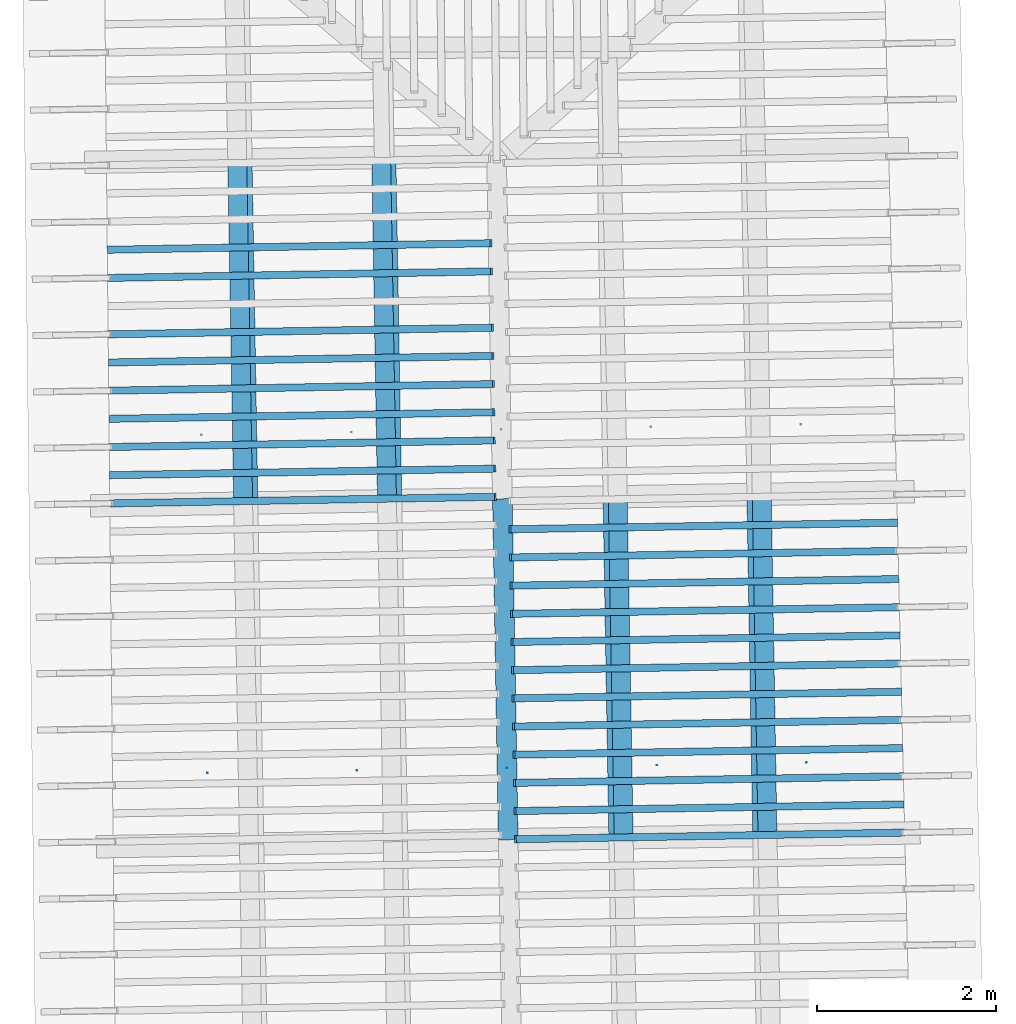
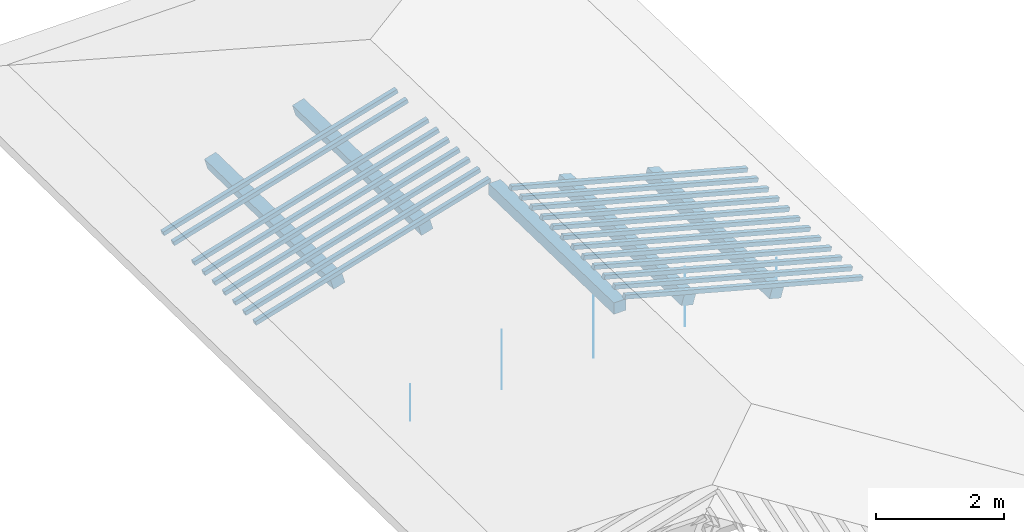
# One storey, part 5 of 19: 22 beams, 5 members, 2 elements without a shape of their own.
"""IFC4 building model written with IfcOpenShell, lengths in metres."""

from ifc_helpers import new_model, entity, si_unit, converted_unit, derived_unit, direction, frame, origin, place, context, subcontext, project, spatial, arc, indexed_curve, outline, extrude, source, transform, mapped, material, type_object, type_shapes, element, aggregate, save


model = new_model("IFC4")

# Units and contexts
model_context = context("Model", 3, precision=1e-05, world=origin(), true_north=direction((6.123233995736766e-17, 1.0)))
body_context = subcontext(model_context, "Body", "Model", "MODEL_VIEW")
ifc_project = project(units=[si_unit("LENGTHUNIT", "METRE"), si_unit("AREAUNIT", "SQUARE_METRE"), si_unit("VOLUMEUNIT", "CUBIC_METRE"), converted_unit("PLANEANGLEUNIT", "DEGREE", entity("IfcPlaneAngleMeasure", 0.017453292519943278), si_unit("PLANEANGLEUNIT", "RADIAN"), dimensions=[0, 0, 0, 0, 0, 0, 0]), derived_unit("THERMALTRANSMITTANCEUNIT", [(si_unit("MASSUNIT", "GRAM", prefix="KILO"), 1), (si_unit("THERMODYNAMICTEMPERATUREUNIT", "KELVIN"), -1), (si_unit("TIMEUNIT", "SECOND"), -3)])], contexts=[model_context])

# Site, building, storey
site_placement = place(None, origin())
site = spatial("IfcSite", under=ifc_project, at=site_placement, CompositionType="ELEMENT")
building_placement = place(site_placement, origin())
building = spatial("IfcBuilding", under=site, at=building_placement, CompositionType="ELEMENT")
storey_placement = place(building_placement, frame((0.0, 0.0, 3.28)))
storey = spatial("IfcBuildingStorey", under=building, at=storey_placement, Name="Livello Copertura", CompositionType="ELEMENT", Elevation=3.28)

# Members
ifc_material_1 = material(Name="Legno - Legno da costruzione", Category="Legno")
member_type_1 = type_object("IfcMemberType", Name="Legno:220x220", PredefinedType="PURLIN", material=ifc_material_1)
shared_shape_1 = source(origin(), body_context, "Body", "SweptSolid", [
    extrude(outline(indexed_curve([(-1.9059999897376847, -0.11000000000000167), (1.9059999897376847, -0.11000000000000167), (1.9059999897376847, 0.11000000000000167), (-1.9059999897376847, 0.11000000000000167), (-1.9059999897376847, -0.11000000000000167)], self_intersect=False)), frame((1.0262315541353928e-08, 0.0, -0.11000000000000543), z_axis=(0.0, 0.0, 1.0), x_axis=(-1.0, 0.0, 0.0)), (0.0, 0.0, 1.0), 0.21999999999999986),
])
type_shapes(member_type_1, [shared_shape_1])
member_placement = place(storey_placement, frame((-0.2062576255729681, 6.6317139072139595, 1.12884073837279), z_axis=(0.0, 0.0, 1.0), x_axis=(0.017084897015610563, -0.9998540424951864, 0.0)))
element("IfcMember", 1, at=member_placement, inside=storey, type_object=member_type_1, material=ifc_material_1, Name="Legno:220x220", ObjectType="Legno:220x220", PredefinedType="PURLIN", context=body_context, shape_type="MappedRepresentation", body=[
    mapped(shared_shape_1, transform((0.0, 0.0, 0.0), scale=1.0)),
])
member_type_2 = type_object("IfcMemberType", Name="Legno:220x220", PredefinedType="PURLIN", material=ifc_material_1)
shared_shape_2 = source(origin(), body_context, "Body", "SweptSolid", [
    extrude(outline(indexed_curve([(-1.905999989737685, -0.11000000000000167), (1.9059999897376847, -0.11000000000000167), (1.905999989737685, 0.11000000000000167), (-1.905999989737685, 0.11000000000000167), (-1.905999989737685, -0.11000000000000167)], self_intersect=False)), frame((1.0262315338316342e-08, 0.0, -0.11000000000000543), z_axis=(0.0, 0.0, 1.0), x_axis=(-1.0, 0.0, 0.0)), (0.0, 0.0, 1.0), 0.21999999999999986),
])
type_shapes(member_type_2, [shared_shape_2])
for number, where, z_axis, x_axis, name in (
    (2, (1.0540890021597151, 6.653124444591353, 0.8159721265451645), (0.2688805697492535, 0.004594467440668277, 0.9631625667976581), (0.01708489701561056, -0.9998540424951863, 0.0), "Legno:220x220"),
    (3, (2.6621509365891316, 6.680506746443959, 0.36692808026980417), (0.2688805697492535, 0.004594467440668277, 0.9631625667976581), (0.01708489701561056, -0.9998540424951863, 0.0), "Legno:220x220"),
):
    element("IfcMember", number, at=place(storey_placement, frame(where, z_axis=z_axis, x_axis=x_axis)), inside=storey, type_object=member_type_2, material=ifc_material_1, Name=name, ObjectType="Legno:220x220", PredefinedType="PURLIN", context=body_context, shape_type="MappedRepresentation", body=[
        mapped(shared_shape_2, transform((0.0, 0.0, 0.0), scale=1.0)),
    ])
member_type_3 = type_object("IfcMemberType", Name="Legno:220x220", PredefinedType="PURLIN", material=ifc_material_1)
shared_shape_3 = source(origin(), body_context, "Body", "SweptSolid", [
    extrude(outline(indexed_curve([(-1.9189999897376846, -0.11000000000000167), (1.9189999897376848, -0.11000000000000167), (1.9189999897376846, 0.11000000000000167), (-1.9189999897376846, 0.11000000000000167), (-1.9189999897376846, -0.11000000000000167)], self_intersect=False)), frame((1.0262315473674733e-08, 0.0, -0.11000000000000543), z_axis=(0.0, 0.0, 1.0), x_axis=(-1.0, 0.0, 0.0)), (0.0, 0.0, 1.0), 0.21999999999999986),
])
type_shapes(member_type_3, [shared_shape_3])
for number, where, z_axis, x_axis, name in (
    (4, (-1.5319733064987866, 10.434952193913192, 0.8160286470518429), (-0.2688805697492535, -0.0045944674406682715, 0.9631625667976581), (0.017084897015610542, -0.9998540424951863, 0.0), "Legno:220x220"),
    (5, (-3.1400352409282095, 10.40756989206059, 0.366984600776487), (-0.2688805697492535, -0.0045944674406682715, 0.9631625667976581), (0.017084897015610542, -0.9998540424951863, 0.0), "Legno:220x220"),
):
    element("IfcMember", number, at=place(storey_placement, frame(where, z_axis=z_axis, x_axis=x_axis)), inside=storey, type_object=member_type_3, material=ifc_material_1, Name=name, ObjectType="Legno:220x220", PredefinedType="PURLIN", context=body_context, shape_type="MappedRepresentation", body=[
        mapped(shared_shape_3, transform((0.0, 0.0, 0.0), scale=1.0)),
    ])

# Beam
ifc_material_2 = material(Name="Metallo - Acciaio - 345 MPa", Category="Metallo")
beam_type_1 = type_object("IfcBeamType", Name="Porta", PredefinedType="BEAM", material=ifc_material_2)
shared_shape_4 = source(origin(), body_context, "Body", "SweptSolid", [
    extrude(outline(indexed_curve([(-0.0025, 0.0), (-9.341026746681546e-18, -0.002499999999999973), (0.0025, 0.0), (1.5308084989342274e-19, 0.002499999999999973)], segments=[arc(1, 2, 3), arc(3, 4, 1)], self_intersect=False)), frame((3.3500000000000014, 0.0, 0.01799999999999821), z_axis=(0.0, 0.0, 1.0), x_axis=(0.0, -1.0, 0.0)), (0.0, 0.0, 1.0), 0.7000000000000034),
    extrude(outline(indexed_curve([(-0.0025, 0.0), (-9.341026746681546e-18, -0.002499999999999973), (0.0025, 0.0), (1.5308084989342274e-19, 0.002499999999999973)], segments=[arc(1, 2, 3), arc(3, 4, 1)], self_intersect=False)), frame((-3.350000000000001, 0.0, 0.01799999999999821), z_axis=(0.0, 0.0, 1.0), x_axis=(0.0, -1.0, 0.0)), (0.0, 0.0, 1.0), 0.7000000000000034),
    extrude(outline(indexed_curve([(-0.0025, 0.0), (-9.341026746681546e-18, -0.002499999999999973), (0.0025, 0.0), (1.5308084989342274e-19, 0.002499999999999973)], segments=[arc(1, 2, 3), arc(3, 4, 1)], self_intersect=False)), frame((1.6750000000000014, 0.0, 0.01799999999999821), z_axis=(0.0, 0.0, 1.0), x_axis=(0.0, -1.0, 0.0)), (0.0, 0.0, 1.0), 1.1350000000000036),
    extrude(outline(indexed_curve([(-0.0025, 0.0), (-9.341026746681546e-18, -0.002499999999999973), (0.0025, 0.0), (1.5308084989342274e-19, 0.002499999999999973)], segments=[arc(1, 2, 3), arc(3, 4, 1)], self_intersect=False)), frame((-1.6749999999999987, 0.0, 0.01799999999999821), z_axis=(0.0, 0.0, 1.0), x_axis=(0.0, -1.0, 0.0)), (0.0, 0.0, 1.0), 1.1350000000000036),
    extrude(outline(indexed_curve([(-0.0025, 4.038861436081489e-18), (-1.8222810943682823e-17, -0.0025000000000000044), (0.0025, -4.0388614360814286e-18), (3.483749923768857e-18, 0.0024999999999999957)], segments=[arc(1, 2, 3), arc(3, 4, 1)], self_intersect=False)), frame((0.0, 0.0, 0.017999999999998344), z_axis=(0.0, 0.0, 1.0), x_axis=(0.0, -1.0, 0.0)), (0.0, 0.0, 1.0), 1.350000000000003),
])
type_shapes(beam_type_1, [shared_shape_4])
beam_1_placement = place(storey_placement, frame((-0.187319978848314, 5.530358983964, -0.3492000000000056), z_axis=(0.0, 0.0, 1.0), x_axis=(0.9998547874088545, 0.017041246890830943, 0.0)))
element("IfcBeam", 6, at=beam_1_placement, inside=storey, type_object=beam_type_1, material=ifc_material_2, Name="Porta", ObjectType="Porta", PredefinedType="BEAM", context=body_context, shape_type="MappedRepresentation", body=[
    mapped(shared_shape_4, transform((0.0, 0.0, 0.0), scale=1.0)),
])

# Assembly, beams
assembly_1_placement = place(storey_placement, origin())
assembly_1 = element("IfcElementAssembly", 7, at=assembly_1_placement, inside=storey, Name="Sistema di travi strutturali:Sistema di travi strutturali", ObjectType="Sistema di travi strutturali:Sistema di travi strutturali", AssemblyPlace="NOTDEFINED", PredefinedType="BEAM_GRID")
beam_type_2 = type_object("IfcBeamType", Name="Legno:80x80", PredefinedType="JOIST", material=ifc_material_1)
shared_shape_5 = source(origin(), body_context, "Body", "SweptSolid", [
    extrude(outline(indexed_curve([(-2.221, -0.04000000000000169), (2.221, -0.04000000000000169), (2.221, 0.04000000000000169), (-2.221, 0.04000000000000169), (-2.221, -0.04000000000000169)], self_intersect=False)), frame((0.0, 0.0, -0.040000000000005476), z_axis=(0.0, 0.0, 1.0), x_axis=(-1.0, 0.0, 0.0)), (0.0, 0.0, 1.0), 0.07999999999999997),
])
type_shapes(beam_type_2, [shared_shape_5])
beam_2_placement = place(assembly_1_placement, frame((-2.5056819045365377, 11.357315051475533, 0.7041569624964674), z_axis=(-0.26888056974925356, -0.0045944674406682776, 0.9631625667976582), x_axis=(0.9630219859926786, 0.016455533263027042, 0.2689198206152655)))
beam_2 = element("IfcBeam", 8, at=beam_2_placement, type_object=beam_type_2, material=ifc_material_1, Name="Legno:80x80", ObjectType="Legno:80x80", PredefinedType="JOIST", context=body_context, shape_type="MappedRepresentation", body=[
    mapped(shared_shape_5, transform((0.0, 0.0, 0.0), scale=1.0)),
])
beam_type_3 = type_object("IfcBeamType", Name="Legno:80x80", PredefinedType="JOIST", material=ifc_material_1)
shared_shape_6 = source(origin(), body_context, "Body", "SweptSolid", [
    extrude(outline(indexed_curve([(-2.222, -0.04000000000000169), (2.222, -0.04000000000000169), (2.222, 0.04000000000000169), (-2.222, 0.04000000000000169), (-2.222, -0.04000000000000169)], self_intersect=False)), frame((0.0, 0.0, -0.040000000000005476), z_axis=(0.0, 0.0, 1.0), x_axis=(-1.0, 0.0, 0.0)), (0.0, 0.0, 1.0), 0.07999999999999997),
])
type_shapes(beam_type_3, [shared_shape_6])
beam_3_placement = place(assembly_1_placement, frame((-2.501447441501872, 11.042341424075659, 0.7038365895365427), z_axis=(-0.2688805697492535, -0.004594467440668277, 0.9631625667976583), x_axis=(0.9630219859926786, 0.016455533263027046, 0.2689198206152654)))
beam_3 = element("IfcBeam", 9, at=beam_3_placement, type_object=beam_type_3, material=ifc_material_1, Name="Legno:80x80", ObjectType="Legno:80x80", PredefinedType="JOIST", context=body_context, shape_type="MappedRepresentation", body=[
    mapped(shared_shape_6, transform((0.0, 0.0, 0.0), scale=1.0)),
])
beam_type_4 = type_object("IfcBeamType", Name="Legno:80x80", PredefinedType="JOIST", material=ifc_material_1)
shared_shape_7 = source(origin(), body_context, "Body", "SweptSolid", [
    extrude(outline(indexed_curve([(-2.2245, -0.04000000000000169), (2.2245, -0.04000000000000169), (2.2245, 0.04000000000000169), (-2.2245, 0.04000000000000169), (-2.2245, -0.04000000000000169)], self_intersect=False)), frame((0.0, 0.0, -0.040000000000005476), z_axis=(0.0, 0.0, 1.0), x_axis=(-1.0, 0.0, 0.0)), (0.0, 0.0, 1.0), 0.07999999999999997),
])
type_shapes(beam_type_4, [shared_shape_7])
beam_4_placement = place(assembly_1_placement, frame((-2.492978515432543, 10.41239416927591, 0.7031958436166895), z_axis=(-0.2688805697492535, -0.004594467440668277, 0.9631625667976583), x_axis=(0.9630219859926786, 0.01645553326302706, 0.2689198206152654)))
beam_4 = element("IfcBeam", 10, at=beam_4_placement, type_object=beam_type_4, material=ifc_material_1, Name="Legno:80x80", ObjectType="Legno:80x80", PredefinedType="JOIST", context=body_context, shape_type="MappedRepresentation", body=[
    mapped(shared_shape_7, transform((0.0, 0.0, 0.0), scale=1.0)),
])
beam_type_5 = type_object("IfcBeamType", Name="Legno:80x80", PredefinedType="JOIST", material=ifc_material_1)
shared_shape_8 = source(origin(), body_context, "Body", "SweptSolid", [
    extrude(outline(indexed_curve([(-2.2255000000000003, -0.04000000000000169), (2.2255000000000003, -0.04000000000000169), (2.2255000000000003, 0.04000000000000169), (-2.2255000000000003, 0.04000000000000169), (-2.2255000000000003, -0.04000000000000169)], self_intersect=False)), frame((0.0, 0.0, -0.040000000000005476), z_axis=(0.0, 0.0, 1.0), x_axis=(-1.0, 0.0, 0.0)), (0.0, 0.0, 1.0), 0.07999999999999997),
])
type_shapes(beam_type_5, [shared_shape_8])
beam_5_placement = place(assembly_1_placement, frame((-2.4887440523978785, 10.097420541876037, 0.7028754706567639), z_axis=(-0.2688805697492535, -0.004594467440668275, 0.9631625667976583), x_axis=(0.9630219859926786, 0.016455533263027067, 0.2689198206152654)))
beam_5 = element("IfcBeam", 11, at=beam_5_placement, type_object=beam_type_5, material=ifc_material_1, Name="Legno:80x80", ObjectType="Legno:80x80", PredefinedType="JOIST", context=body_context, shape_type="MappedRepresentation", body=[
    mapped(shared_shape_8, transform((0.0, 0.0, 0.0), scale=1.0)),
])
beam_type_6 = type_object("IfcBeamType", Name="Legno:80x80", PredefinedType="JOIST", material=ifc_material_1)
shared_shape_9 = source(origin(), body_context, "Body", "SweptSolid", [
    extrude(outline(indexed_curve([(-2.227, -0.04000000000000169), (2.227, -0.04000000000000169), (2.227, 0.04000000000000169), (-2.227, 0.04000000000000169), (-2.227, -0.04000000000000169)], self_intersect=False)), frame((0.0, 0.0, -0.040000000000005476), z_axis=(0.0, 0.0, 1.0), x_axis=(-1.0, 0.0, 0.0)), (0.0, 0.0, 1.0), 0.07999999999999997),
])
type_shapes(beam_type_6, [shared_shape_9])
beam_6_placement = place(assembly_1_placement, frame((-2.484509589363214, 9.782446914476164, 0.7025550976968373), z_axis=(-0.2688805697492536, -0.004594467440668278, 0.9631625667976582), x_axis=(0.9630219859926786, 0.016455533263026827, 0.26891982061526554)))
beam_6 = element("IfcBeam", 12, at=beam_6_placement, type_object=beam_type_6, material=ifc_material_1, Name="Legno:80x80", ObjectType="Legno:80x80", PredefinedType="JOIST", context=body_context, shape_type="MappedRepresentation", body=[
    mapped(shared_shape_9, transform((0.0, 0.0, 0.0), scale=1.0)),
])
beam_type_7 = type_object("IfcBeamType", Name="Legno:80x80", PredefinedType="JOIST", material=ifc_material_1)
shared_shape_10 = source(origin(), body_context, "Body", "SweptSolid", [
    extrude(outline(indexed_curve([(-2.228, -0.04000000000000169), (2.228, -0.04000000000000169), (2.228, 0.04000000000000169), (-2.228, 0.04000000000000169), (-2.228, -0.04000000000000169)], self_intersect=False)), frame((0.0, 0.0, -0.040000000000005476), z_axis=(0.0, 0.0, 1.0), x_axis=(-1.0, 0.0, 0.0)), (0.0, 0.0, 1.0), 0.07999999999999997),
])
type_shapes(beam_type_7, [shared_shape_10])
beam_7_placement = place(assembly_1_placement, frame((-2.4802751263285487, 9.46747328707629, 0.7022347247369111), z_axis=(-0.26888056974925345, -0.004594467440668276, 0.9631625667976583), x_axis=(0.9630219859926786, 0.01645553326302684, 0.26891982061526537)))
beam_7 = element("IfcBeam", 13, at=beam_7_placement, type_object=beam_type_7, material=ifc_material_1, Name="Legno:80x80", ObjectType="Legno:80x80", PredefinedType="JOIST", context=body_context, shape_type="MappedRepresentation", body=[
    mapped(shared_shape_10, transform((0.0, 0.0, 0.0), scale=1.0)),
])
beam_type_8 = type_object("IfcBeamType", Name="Legno:80x80", PredefinedType="JOIST", material=ifc_material_1)
shared_shape_11 = source(origin(), body_context, "Body", "SweptSolid", [
    extrude(outline(indexed_curve([(-2.229, -0.04000000000000169), (2.229, -0.04000000000000169), (2.229, 0.04000000000000169), (-2.229, 0.04000000000000169), (-2.229, -0.04000000000000169)], self_intersect=False)), frame((0.0, 0.0, -0.040000000000005476), z_axis=(0.0, 0.0, 1.0), x_axis=(-1.0, 0.0, 0.0)), (0.0, 0.0, 1.0), 0.07999999999999997),
])
type_shapes(beam_type_8, [shared_shape_11])
beam_8_placement = place(assembly_1_placement, frame((-2.476040663293883, 9.152499659676415, 0.7019143517769858), z_axis=(-0.2688805697492535, -0.004594467440668278, 0.9631625667976583), x_axis=(0.9630219859926786, 0.016455533263027084, 0.2689198206152654)))
beam_8 = element("IfcBeam", 14, at=beam_8_placement, type_object=beam_type_8, material=ifc_material_1, Name="Legno:80x80", ObjectType="Legno:80x80", PredefinedType="JOIST", context=body_context, shape_type="MappedRepresentation", body=[
    mapped(shared_shape_11, transform((0.0, 0.0, 0.0), scale=1.0)),
])
beam_type_9 = type_object("IfcBeamType", Name="Legno:80x80", PredefinedType="JOIST", material=ifc_material_1)
shared_shape_12 = source(origin(), body_context, "Body", "SweptSolid", [
    extrude(outline(indexed_curve([(-2.2305, -0.04000000000000169), (2.2305, -0.04000000000000169), (2.2305, 0.04000000000000169), (-2.2305, 0.04000000000000169), (-2.2305, -0.04000000000000169)], self_intersect=False)), frame((0.0, 0.0, -0.040000000000005476), z_axis=(0.0, 0.0, 1.0), x_axis=(-1.0, 0.0, 0.0)), (0.0, 0.0, 1.0), 0.07999999999999997),
])
type_shapes(beam_type_9, [shared_shape_12])
beam_9_placement = place(assembly_1_placement, frame((-2.471806200259219, 8.837526032276541, 0.7015939788170588), z_axis=(-0.2688805697492534, -0.004594467440668275, 0.9631625667976583), x_axis=(0.9630219859926786, 0.016455533263026855, 0.2689198206152653)))
beam_9 = element("IfcBeam", 15, at=beam_9_placement, type_object=beam_type_9, material=ifc_material_1, Name="Legno:80x80", ObjectType="Legno:80x80", PredefinedType="JOIST", context=body_context, shape_type="MappedRepresentation", body=[
    mapped(shared_shape_12, transform((0.0, 0.0, 0.0), scale=1.0)),
])
beam_type_10 = type_object("IfcBeamType", Name="Legno:80x80", PredefinedType="JOIST", material=ifc_material_1)
shared_shape_13 = source(origin(), body_context, "Body", "SweptSolid", [
    extrude(outline(indexed_curve([(-2.2315, -0.04000000000000169), (2.2315, -0.04000000000000169), (2.2315, 0.04000000000000169), (-2.2315, 0.04000000000000169), (-2.2315, -0.04000000000000169)], self_intersect=False)), frame((0.0, 0.0, -0.040000000000005476), z_axis=(0.0, 0.0, 1.0), x_axis=(-1.0, 0.0, 0.0)), (0.0, 0.0, 1.0), 0.07999999999999997),
])
type_shapes(beam_type_10, [shared_shape_13])
beam_10_placement = place(assembly_1_placement, frame((-2.467571737224554, 8.522552404876668, 0.701273605857132), z_axis=(-0.26888056974925345, -0.0045944674406682776, 0.9631625667976583), x_axis=(0.9630219859926786, 0.016455533263027105, 0.26891982061526537)))
beam_10 = element("IfcBeam", 16, at=beam_10_placement, type_object=beam_type_10, material=ifc_material_1, Name="Legno:80x80", ObjectType="Legno:80x80", PredefinedType="JOIST", context=body_context, shape_type="MappedRepresentation", body=[
    mapped(shared_shape_13, transform((0.0, 0.0, 0.0), scale=1.0)),
])
aggregate(assembly_1, [beam_2, beam_3, beam_4, beam_5, beam_6, beam_7, beam_8, beam_9, beam_10])

assembly_2_placement = place(storey_placement, origin())
assembly_2 = element("IfcElementAssembly", 17, at=assembly_2_placement, inside=storey, Name="Sistema di travi strutturali:Sistema di travi strutturali", ObjectType="Sistema di travi strutturali:Sistema di travi strutturali", AssemblyPlace="NOTDEFINED", PredefinedType="BEAM_GRID")
beam_type_11 = type_object("IfcBeamType", Name="Legno:80x80", PredefinedType="JOIST", material=ifc_material_1)
shared_shape_14 = source(origin(), body_context, "Body", "SweptSolid", [
    extrude(outline(indexed_curve([(-2.2425, -0.04000000000000169), (2.2425, -0.04000000000000169), (2.2425, 0.04000000000000169), (-2.2425, 0.04000000000000169), (-2.2425, -0.04000000000000169)], self_intersect=False)), frame((0.0, 0.0, -0.040000000000005476), z_axis=(0.0, 0.0, 1.0), x_axis=(-1.0, 0.0, 0.0)), (0.0, 0.0, 1.0), 0.07999999999999997),
])
type_shapes(beam_type_11, [shared_shape_14])
beam_11_placement = place(assembly_2_placement, frame((2.0058798039037358, 8.233035841120778, 0.6984666208008706), z_axis=(0.2688805697492535, 0.0045944674406682776, 0.9631625667976583), x_axis=(-0.9630219859926786, -0.016455533263027886, 0.2689198206152654)))
beam_11 = element("IfcBeam", 18, at=beam_11_placement, type_object=beam_type_11, material=ifc_material_1, Name="Legno:80x80", ObjectType="Legno:80x80", PredefinedType="JOIST", context=body_context, shape_type="MappedRepresentation", body=[
    mapped(shared_shape_14, transform((0.0, 0.0, 0.0), scale=1.0)),
])
beam_type_12 = type_object("IfcBeamType", Name="Legno:80x80", PredefinedType="JOIST", material=ifc_material_1)
shared_shape_15 = source(origin(), body_context, "Body", "SweptSolid", [
    extrude(outline(indexed_curve([(-2.246, -0.04000000000000169), (2.246, -0.04000000000000169), (2.246, 0.04000000000000169), (-2.246, 0.04000000000000169), (-2.246, -0.04000000000000169)], self_intersect=False)), frame((0.0, 0.0, -0.040000000000005476), z_axis=(0.0, 0.0, 1.0), x_axis=(-1.0, 0.0, 0.0)), (0.0, 0.0, 1.0), 0.07999999999999997),
])
type_shapes(beam_type_12, [shared_shape_15])
beam_12_placement = place(assembly_2_placement, frame((2.025059217244707, 7.288225617279735, 0.6976193372750571), z_axis=(0.26888056974925356, 0.004594467440668277, 0.9631625667976582), x_axis=(-0.9630219859926786, -0.016455533263027896, 0.2689198206152655)))
beam_12 = element("IfcBeam", 19, at=beam_12_placement, type_object=beam_type_12, material=ifc_material_1, Name="Legno:80x80", ObjectType="Legno:80x80", PredefinedType="JOIST", context=body_context, shape_type="MappedRepresentation", body=[
    mapped(shared_shape_15, transform((0.0, 0.0, 0.0), scale=1.0)),
])
beam_type_13 = type_object("IfcBeamType", Name="Legno:80x80", PredefinedType="JOIST", material=ifc_material_1)
shared_shape_16 = source(origin(), body_context, "Body", "SweptSolid", [
    extrude(outline(indexed_curve([(-2.247, -0.04000000000000169), (2.247, -0.04000000000000169), (2.247, 0.04000000000000169), (-2.247, 0.04000000000000169), (-2.247, -0.04000000000000169)], self_intersect=False)), frame((0.0, 0.0, -0.040000000000005476), z_axis=(0.0, 0.0, 1.0), x_axis=(-1.0, 0.0, 0.0)), (0.0, 0.0, 1.0), 0.07999999999999997),
])
type_shapes(beam_type_13, [shared_shape_16])
beam_13_placement = place(assembly_2_placement, frame((2.0314523550250305, 6.973288875999387, 0.697336909433118), z_axis=(0.2688805697492535, 0.004594467440668277, 0.9631625667976583), x_axis=(-0.9630219859926786, -0.016455533263027896, 0.2689198206152654)))
beam_13 = element("IfcBeam", 20, at=beam_13_placement, type_object=beam_type_13, material=ifc_material_1, Name="Legno:80x80", ObjectType="Legno:80x80", PredefinedType="JOIST", context=body_context, shape_type="MappedRepresentation", body=[
    mapped(shared_shape_16, transform((0.0, 0.0, 0.0), scale=1.0)),
])
beam_type_14 = type_object("IfcBeamType", Name="Legno:80x80", PredefinedType="JOIST", material=ifc_material_1)
shared_shape_17 = source(origin(), body_context, "Body", "SweptSolid", [
    extrude(outline(indexed_curve([(-2.252, -0.04000000000000169), (2.252, -0.04000000000000169), (2.252, 0.04000000000000169), (-2.252, 0.04000000000000169), (-2.252, -0.04000000000000169)], self_intersect=False)), frame((0.0, 0.0, -0.040000000000005476), z_axis=(0.0, 0.0, 1.0), x_axis=(-1.0, 0.0, 0.0)), (0.0, 0.0, 1.0), 0.07999999999999997),
])
type_shapes(beam_type_14, [shared_shape_17])
beam_14_placement = place(assembly_2_placement, frame((2.0634180439266494, 5.398605169597649, 0.695924770223428), z_axis=(0.26888056974925356, 0.0045944674406682776, 0.9631625667976583), x_axis=(-0.9630219859926786, -0.016455533263027913, 0.2689198206152655)))
beam_14 = element("IfcBeam", 21, at=beam_14_placement, type_object=beam_type_14, material=ifc_material_1, Name="Legno:80x80", ObjectType="Legno:80x80", PredefinedType="JOIST", context=body_context, shape_type="MappedRepresentation", body=[
    mapped(shared_shape_17, transform((0.0, 0.0, 0.0), scale=1.0)),
])
beam_type_15 = type_object("IfcBeamType", Name="Legno:80x80", PredefinedType="JOIST", material=ifc_material_1)
shared_shape_18 = source(origin(), body_context, "Body", "SweptSolid", [
    extrude(outline(indexed_curve([(-2.253, -0.04000000000000169), (2.253, -0.04000000000000169), (2.253, 0.04000000000000169), (-2.253, 0.04000000000000169), (-2.253, -0.04000000000000169)], self_intersect=False)), frame((0.0, 0.0, -0.040000000000005476), z_axis=(0.0, 0.0, 1.0), x_axis=(-1.0, 0.0, 0.0)), (0.0, 0.0, 1.0), 0.07999999999999997),
])
type_shapes(beam_type_15, [shared_shape_18])
beam_15_placement = place(assembly_2_placement, frame((2.069811181706972, 5.083668428317299, 0.6956423423814905), z_axis=(0.2688805697492534, 0.004594467440668275, 0.9631625667976583), x_axis=(-0.9630219859926786, -0.016455533263027913, 0.2689198206152653)))
beam_15 = element("IfcBeam", 22, at=beam_15_placement, type_object=beam_type_15, material=ifc_material_1, Name="Legno:80x80", ObjectType="Legno:80x80", PredefinedType="JOIST", context=body_context, shape_type="MappedRepresentation", body=[
    mapped(shared_shape_18, transform((0.0, 0.0, 0.0), scale=1.0)),
])
beam_type_16 = type_object("IfcBeamType", Name="Legno:80x80", PredefinedType="JOIST", material=ifc_material_1)
shared_shape_19 = source(origin(), body_context, "Body", "SweptSolid", [
    extrude(outline(indexed_curve([(-2.249, -0.04000000000000169), (2.249, -0.04000000000000169), (2.249, 0.04000000000000169), (-2.249, 0.04000000000000169), (-2.249, -0.04000000000000169)], self_intersect=False)), frame((0.0, 0.0, -0.040000000000005476), z_axis=(0.0, 0.0, 1.0), x_axis=(-1.0, 0.0, 0.0)), (0.0, 0.0, 1.0), 0.07999999999999997),
])
type_shapes(beam_type_16, [shared_shape_19])
beam_16_placement = place(assembly_2_placement, frame((2.0442386305856775, 6.34341539343869, 0.6967720537492424), z_axis=(0.26888056974925356, 0.004594467440668277, 0.9631625667976582), x_axis=(-0.9630219859926786, -0.016455533263027903, 0.2689198206152655)))
beam_16 = element("IfcBeam", 23, at=beam_16_placement, type_object=beam_type_16, material=ifc_material_1, Name="Legno:80x80", ObjectType="Legno:80x80", PredefinedType="JOIST", context=body_context, shape_type="MappedRepresentation", body=[
    mapped(shared_shape_19, transform((0.0, 0.0, 0.0), scale=1.0)),
])
beam_type_17 = type_object("IfcBeamType", Name="Legno:80x80", PredefinedType="JOIST", material=ifc_material_1)
shared_shape_20 = source(origin(), body_context, "Body", "SweptSolid", [
    extrude(outline(indexed_curve([(-2.2545, -0.04000000000000169), (2.2545, -0.04000000000000169), (2.2545, 0.04000000000000169), (-2.2545, 0.04000000000000169), (-2.2545, -0.04000000000000169)], self_intersect=False)), frame((0.0, 0.0, -0.040000000000005476), z_axis=(0.0, 0.0, 1.0), x_axis=(-1.0, 0.0, 0.0)), (0.0, 0.0, 1.0), 0.07999999999999997),
])
type_shapes(beam_type_17, [shared_shape_20])
beam_17_placement = place(assembly_2_placement, frame((2.076204319487296, 4.768731687036951, 0.6953599145395526), z_axis=(0.2688805697492536, 0.004594467440668277, 0.9631625667976583), x_axis=(-0.9630219859926786, -0.016455533263027913, 0.26891982061526554)))
beam_17 = element("IfcBeam", 24, at=beam_17_placement, type_object=beam_type_17, material=ifc_material_1, Name="Legno:80x80", ObjectType="Legno:80x80", PredefinedType="JOIST", context=body_context, shape_type="MappedRepresentation", body=[
    mapped(shared_shape_20, transform((0.0, 0.0, 0.0), scale=1.0)),
])
beam_type_18 = type_object("IfcBeamType", Name="Legno:80x80", PredefinedType="JOIST", material=ifc_material_1)
shared_shape_21 = source(origin(), body_context, "Body", "SweptSolid", [
    extrude(outline(indexed_curve([(-2.251, -0.04000000000000169), (2.251, -0.04000000000000169), (2.251, 0.04000000000000169), (-2.251, 0.04000000000000169), (-2.251, -0.04000000000000169)], self_intersect=False)), frame((0.0, 0.0, -0.040000000000005476), z_axis=(0.0, 0.0, 1.0), x_axis=(-1.0, 0.0, 0.0)), (0.0, 0.0, 1.0), 0.07999999999999997),
])
type_shapes(beam_type_18, [shared_shape_21])
beam_18_placement = place(assembly_2_placement, frame((2.057024906146325, 5.713541910877995, 0.6962071980653668), z_axis=(0.2688805697492535, 0.004594467440668276, 0.9631625667976582), x_axis=(-0.9630219859926786, -0.01645553326302791, 0.2689198206152654)))
beam_18 = element("IfcBeam", 25, at=beam_18_placement, type_object=beam_type_18, material=ifc_material_1, Name="Legno:80x80", ObjectType="Legno:80x80", PredefinedType="JOIST", context=body_context, shape_type="MappedRepresentation", body=[
    mapped(shared_shape_21, transform((0.0, 0.0, 0.0), scale=1.0)),
])
beam_type_19 = type_object("IfcBeamType", Name="Legno:80x80", PredefinedType="JOIST", material=ifc_material_1)
shared_shape_22 = source(origin(), body_context, "Body", "SweptSolid", [
    extrude(outline(indexed_curve([(-2.25, -0.04000000000000169), (2.25, -0.04000000000000169), (2.25, 0.04000000000000169), (-2.25, 0.04000000000000169), (-2.25, -0.04000000000000169)], self_intersect=False)), frame((0.0, 0.0, -0.040000000000005476), z_axis=(0.0, 0.0, 1.0), x_axis=(-1.0, 0.0, 0.0)), (0.0, 0.0, 1.0), 0.07999999999999997),
])
type_shapes(beam_type_19, [shared_shape_22])
beam_19_placement = place(assembly_2_placement, frame((2.050631768366001, 6.028478652158344, 0.6964896259073048), z_axis=(0.2688805697492536, 0.0045944674406682776, 0.9631625667976582), x_axis=(-0.9630219859926786, -0.016455533263027906, 0.26891982061526554)))
beam_19 = element("IfcBeam", 26, at=beam_19_placement, type_object=beam_type_19, material=ifc_material_1, Name="Legno:80x80", ObjectType="Legno:80x80", PredefinedType="JOIST", context=body_context, shape_type="MappedRepresentation", body=[
    mapped(shared_shape_22, transform((0.0, 0.0, 0.0), scale=1.0)),
])
beam_type_20 = type_object("IfcBeamType", Name="Legno:80x80", PredefinedType="JOIST", material=ifc_material_1)
shared_shape_23 = source(origin(), body_context, "Body", "SweptSolid", [
    extrude(outline(indexed_curve([(-2.248, -0.04000000000000169), (2.248, -0.04000000000000169), (2.248, 0.04000000000000169), (-2.248, 0.04000000000000169), (-2.248, -0.04000000000000169)], self_intersect=False)), frame((0.0, 0.0, -0.040000000000005476), z_axis=(0.0, 0.0, 1.0), x_axis=(-1.0, 0.0, 0.0)), (0.0, 0.0, 1.0), 0.07999999999999997),
])
type_shapes(beam_type_20, [shared_shape_23])
beam_20_placement = place(assembly_2_placement, frame((2.037845492805354, 6.658352134719038, 0.6970544815911804), z_axis=(0.26888056974925356, 0.0045944674406682776, 0.9631625667976583), x_axis=(-0.9630219859926786, -0.016455533263027903, 0.2689198206152655)))
beam_20 = element("IfcBeam", 27, at=beam_20_placement, type_object=beam_type_20, material=ifc_material_1, Name="Legno:80x80", ObjectType="Legno:80x80", PredefinedType="JOIST", context=body_context, shape_type="MappedRepresentation", body=[
    mapped(shared_shape_23, transform((0.0, 0.0, 0.0), scale=1.0)),
])
beam_type_21 = type_object("IfcBeamType", Name="Legno:80x80", PredefinedType="JOIST", material=ifc_material_1)
shared_shape_24 = source(origin(), body_context, "Body", "SweptSolid", [
    extrude(outline(indexed_curve([(-2.245, -0.04000000000000169), (2.245, -0.04000000000000169), (2.245, 0.04000000000000169), (-2.245, 0.04000000000000169), (-2.245, -0.04000000000000169)], self_intersect=False)), frame((0.0, 0.0, -0.040000000000005476), z_axis=(0.0, 0.0, 1.0), x_axis=(-1.0, 0.0, 0.0)), (0.0, 0.0, 1.0), 0.07999999999999997),
])
type_shapes(beam_type_21, [shared_shape_24])
beam_21_placement = place(assembly_2_placement, frame((2.018666079464383, 7.603162358560085, 0.6979017651169953), z_axis=(0.2688805697492535, 0.004594467440668277, 0.9631625667976583), x_axis=(-0.9630219859926786, -0.01645553326302789, 0.2689198206152654)))
beam_21 = element("IfcBeam", 28, at=beam_21_placement, type_object=beam_type_21, material=ifc_material_1, Name="Legno:80x80", ObjectType="Legno:80x80", PredefinedType="JOIST", context=body_context, shape_type="MappedRepresentation", body=[
    mapped(shared_shape_24, transform((0.0, 0.0, 0.0), scale=1.0)),
])
beam_type_22 = type_object("IfcBeamType", Name="Legno:80x80", PredefinedType="JOIST", material=ifc_material_1)
shared_shape_25 = source(origin(), body_context, "Body", "SweptSolid", [
    extrude(outline(indexed_curve([(-2.244, -0.04000000000000169), (2.244, -0.04000000000000169), (2.244, 0.04000000000000169), (-2.244, 0.04000000000000169), (-2.244, -0.04000000000000169)], self_intersect=False)), frame((0.0, 0.0, -0.040000000000005476), z_axis=(0.0, 0.0, 1.0), x_axis=(-1.0, 0.0, 0.0)), (0.0, 0.0, 1.0), 0.07999999999999997),
])
type_shapes(beam_type_22, [shared_shape_25])
beam_22_placement = place(assembly_2_placement, frame((2.0122729416840595, 7.918099099840432, 0.6981841929589333), z_axis=(0.2688805697492534, 0.004594467440668274, 0.9631625667976583), x_axis=(-0.9630219859926786, -0.01645553326302789, 0.2689198206152653)))
beam_22 = element("IfcBeam", 29, at=beam_22_placement, type_object=beam_type_22, material=ifc_material_1, Name="Legno:80x80", ObjectType="Legno:80x80", PredefinedType="JOIST", context=body_context, shape_type="MappedRepresentation", body=[
    mapped(shared_shape_25, transform((0.0, 0.0, 0.0), scale=1.0)),
])
aggregate(assembly_2, [beam_17, beam_15, beam_14, beam_18, beam_19, beam_16, beam_20, beam_13, beam_12, beam_21, beam_22, beam_11])

save(model, "model.ifc")
